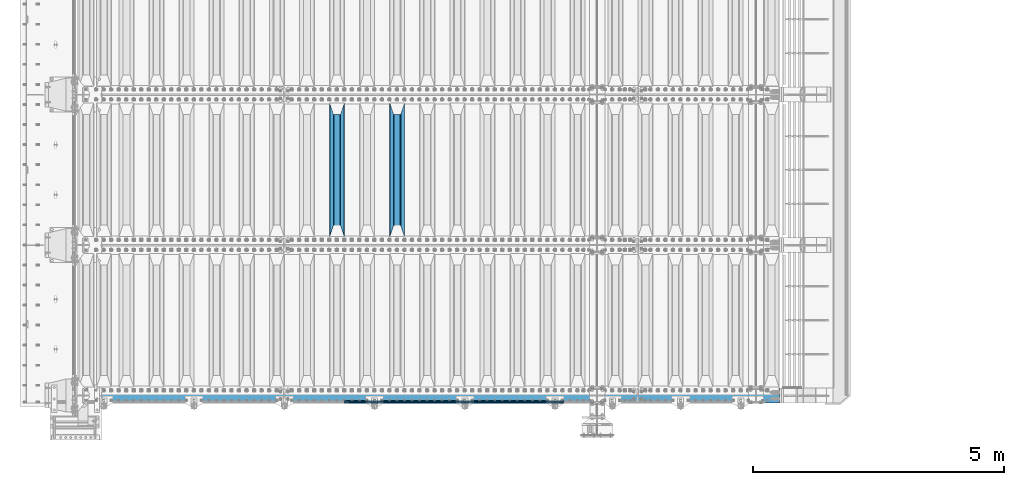
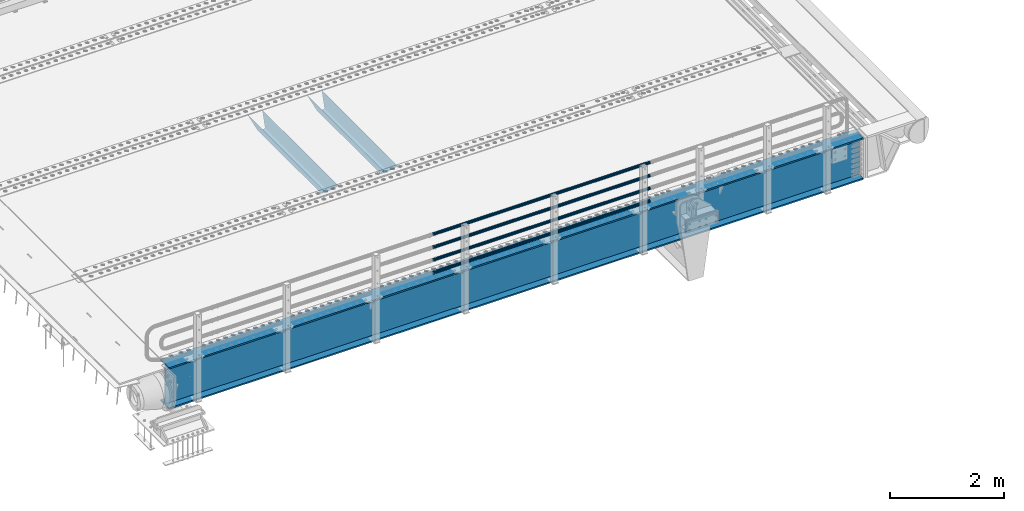
# One storey, part 104 of 240: 7 beams.
"""IFC2X3 building model written with IfcOpenShell, lengths in millimetres."""

import ifcopenshell
import ifcopenshell.guid

model = None  # the IFC model being written
_history = None  # IfcOwnerHistory: only IFC2X3 demands one
_inside = {}  # id of a spatial element -> (the spatial element, [elements in it])
_under = {}  # id of a project, library or spatial element -> (it, [spatial elements below it])
_declared = {}  # id of a project -> (the project, [libraries it declares])
_typed = {}  # id of a type object -> (the type object, [elements of that type])
_made_of = {}  # id of a material, layer set ... -> (it, [elements and type objects made of it])


def new_model(schema):
    """Start an empty IFC model of exactly this schema.

    Asked for "IFC4X3", IfcOpenShell would pick the latest addendum, in which some entities
    have other attributes; the version numbers below select the first issue.
    IFC2X3 requires an IfcOwnerHistory on every rooted entity: one is made here for all.
    """
    global model, _history
    if schema == "IFC4X3":
        model = ifcopenshell.file(schema_version=(4, 3, 0, 0))
    else:
        model = ifcopenshell.file(schema=schema)
    _inside.clear()
    _under.clear()
    _declared.clear()
    _typed.clear()
    _made_of.clear()
    _history = None
    if model.schema == "IFC2X3":
        org = make("IfcOrganization", Name="unknown")
        user = make(
            "IfcPersonAndOrganization",
            ThePerson=make("IfcPerson", FamilyName="unknown"),
            TheOrganization=org,
        )
        app = make(
            "IfcApplication",
            ApplicationDeveloper=org,
            Version="unknown",
            ApplicationFullName="unknown",
            ApplicationIdentifier="unknown",
        )
        _history = make(
            "IfcOwnerHistory",
            OwningUser=user,
            OwningApplication=app,
            ChangeAction="ADDED",
            CreationDate=0,
        )
    return model


def make(cls, **values):
    """One entity of the class cls with the attributes given. An attribute that is None is left unset."""
    return model.create_entity(
        cls, **{name: value for name, value in values.items() if value is not None}
    )


def rooted(cls, **values):
    """An entity with a GlobalId (a new one), such as an element, a storey or a relation."""
    return make(cls, GlobalId=ifcopenshell.guid.new(), OwnerHistory=_history, **values)


def si_unit(unit_type, name, prefix=None):
    """IfcSIUnit, for example si_unit("LENGTHUNIT", "METRE", prefix="MILLI")."""
    return make("IfcSIUnit", UnitType=unit_type, Prefix=prefix, Name=name)


def assignment(units):
    """IfcUnitAssignment: the units of a project."""
    return None if units is None else make("IfcUnitAssignment", Units=units)


def point(xyz):
    """IfcCartesianPoint."""
    return None if xyz is None else make("IfcCartesianPoint", Coordinates=xyz)


def direction(xyz):
    """IfcDirection."""
    return None if xyz is None else make("IfcDirection", DirectionRatios=xyz)


def frame(location, z_axis=None, x_axis=None):
    """IfcAxis2Placement3D, a coordinate frame: its origin and axes. An axis left out is left unset."""
    return make(
        "IfcAxis2Placement3D",
        Location=point(location),
        Axis=direction(z_axis),
        RefDirection=direction(x_axis),
    )


def origin_with_axes():
    """The frame at (0, 0, 0) with the z axis (0, 0, 1) and the x axis (1, 0, 0) written out."""
    return frame((0.0, 0.0, 0.0), z_axis=(0.0, 0.0, 1.0), x_axis=(1.0, 0.0, 0.0))


def place(relative_to, where):
    """IfcLocalPlacement: puts the frame where relative to a parent placement (None: the world)."""
    return make(
        "IfcLocalPlacement", PlacementRelTo=relative_to, RelativePlacement=where
    )


def context(
    kind, dimensions, precision=None, world=None, true_north=None, identifier=None
):
    """IfcGeometricRepresentationContext, for example the 3D "Model" context."""
    return make(
        "IfcGeometricRepresentationContext",
        ContextIdentifier=identifier,
        ContextType=kind,
        CoordinateSpaceDimension=dimensions,
        Precision=precision,
        WorldCoordinateSystem=world,
        TrueNorth=true_north,
    )


def subcontext(parent, identifier, kind, view, scale=None):
    """IfcGeometricRepresentationSubContext, for example "Body" below "Model"."""
    return make(
        "IfcGeometricRepresentationSubContext",
        ContextIdentifier=identifier,
        ContextType=kind,
        ParentContext=parent,
        TargetScale=scale,
        TargetView=view,
    )


def project(units=None, contexts=None):
    """IfcProject with its units and contexts."""
    return rooted(
        "IfcProject",
        Name="project",
        RepresentationContexts=contexts,
        UnitsInContext=assignment(units),
    )


def spatial(cls, under=None, at=None, **own):
    """A site, building, storey or space (cls), placed at a placement, below another one or the project."""
    s = rooted(cls, ObjectPlacement=at, **own)
    if under is not None:
        _under.setdefault(under.id(), (under, []))[1].append(s)
    return s


def faces_of(points, faces, orient=None, outer=None):
    """IfcFace entities. A face is a list of loops; a loop is a list of indices into points, from 0.

    orient and outer hold one flag for each loop. By default every Orientation is true, the
    first loop of a face is its IfcFaceOuterBound and the others are IfcFaceBound.
    """
    made = []
    for i, loops in enumerate(faces):
        bounds = []
        for j, loop in enumerate(loops):
            is_outer = j == 0 if outer is None else outer[i][j]
            bounds.append(
                make(
                    "IfcFaceOuterBound" if is_outer else "IfcFaceBound",
                    Bound=make("IfcPolyLoop", Polygon=[points[k] for k in loop]),
                    Orientation=True if orient is None else orient[i][j],
                )
            )
        made.append(make("IfcFace", Bounds=bounds))
    return made


def faceted_brep(points, faces, orient=None, outer=None, voids=None):
    """IfcFacetedBrep: a solid bounded by flat faces; with voids (closed shells), ...WithVoids."""
    shared = [point(p) for p in points]
    hull = make("IfcClosedShell", CfsFaces=faces_of(shared, faces, orient, outer))
    if voids is None:
        return make("IfcFacetedBrep", Outer=hull)
    return make(
        "IfcFacetedBrepWithVoids",
        Outer=hull,
        Voids=[
            make(cls, CfsFaces=faces_of(shared, fs, o, b)) for cls, fs, o, b in voids
        ],
    )


def shape(context_of_items, identifier, shape_type, items):
    """IfcShapeRepresentation: the items that make up one representation, for example the "Body"."""
    return make(
        "IfcShapeRepresentation",
        ContextOfItems=context_of_items,
        RepresentationIdentifier=identifier,
        RepresentationType=shape_type,
        Items=items,
    )


def material(Name=None, Category=None):
    """IfcMaterial."""
    return make("IfcMaterial", Name=Name, Category=Category)


def made_of(thing, what):
    """Note that an element or type object is made of a material, layer set ...; save() writes the relation."""
    if what is not None:
        _made_of.setdefault(what.id(), (what, []))[1].append(thing)
    return thing


def type_object(cls, material=None, **own):
    """A type object (cls), such as IfcWallType, which elements share."""
    return made_of(rooted(cls, **own), material)


def element(
    cls,
    number,
    at=None,
    inside=None,
    cuts=None,
    type_object=None,
    material=None,
    context=None,
    identifier="Body",
    shape_type=None,
    held_by="IfcProductDefinitionShape",
    body=None,
    shapes=None,
    **own,
):
    """One element of the class cls, such as IfcWall. Its Tag is "e" and its number.

    at: its placement. inside: the storey or other place that contains it. cuts: it is an
    opening in that element (IfcRelVoidsElement). A single representation is given by context,
    identifier, shape_type and body (its items); several are given by shapes. held_by: the class
    of the entity that holds the representations. save() writes the other relations.
    """
    e = rooted(cls, Tag="e%d" % number, ObjectPlacement=at, **own)
    if body is not None:
        shapes = [shape(context, identifier, shape_type, body)]
    if shapes is not None:
        e.Representation = make(held_by, Representations=shapes)
    if inside is not None:
        _inside.setdefault(inside.id(), (inside, []))[1].append(e)
    if cuts is not None:
        rooted(
            "IfcRelVoidsElement", RelatingBuildingElement=cuts, RelatedOpeningElement=e
        )
    if type_object is not None:
        _typed.setdefault(type_object.id(), (type_object, []))[1].append(e)
    return made_of(e, material)


def aggregate(whole, parts):
    """IfcRelAggregates: a whole, such as a stair, and the parts it consists of."""
    return rooted("IfcRelAggregates", RelatingObject=whole, RelatedObjects=parts)


def save(model, path):
    """Write the relations noted so far, then the file.

    IfcRelAggregates (storeys below a building ...), IfcRelContainedInSpatialStructure (elements
    in a storey), IfcRelDefinesByType, IfcRelAssociatesMaterial and IfcRelDeclares: one each for
    every whole, place, type object, material and project.
    """
    for whole, parts in _under.values():
        aggregate(whole, parts)
    for where, things in _inside.values():
        rooted(
            "IfcRelContainedInSpatialStructure",
            RelatedElements=things,
            RelatingStructure=where,
        )
    for kind, things in _typed.values():
        rooted("IfcRelDefinesByType", RelatedObjects=things, RelatingType=kind)
    for what, things in _made_of.values():
        rooted("IfcRelAssociatesMaterial", RelatedObjects=things, RelatingMaterial=what)
    for by, libraries in _declared.values():
        rooted("IfcRelDeclares", RelatingContext=by, RelatedDefinitions=libraries)
    model.write(path)


model = new_model("IFC2X3")

# Units and contexts
model_context = context("Model", 3, precision=1e-05, world=origin_with_axes())
body_context = subcontext(model_context, "Body", "Model", "MODEL_VIEW")
ifc_project = project(units=[si_unit("LENGTHUNIT", "METRE", prefix="MILLI"), si_unit("AREAUNIT", "SQUARE_METRE"), si_unit("VOLUMEUNIT", "CUBIC_METRE"), si_unit("MASSUNIT", "GRAM", prefix="KILO"), si_unit("TIMEUNIT", "SECOND"), si_unit("PLANEANGLEUNIT", "RADIAN"), si_unit("SOLIDANGLEUNIT", "STERADIAN"), si_unit("THERMODYNAMICTEMPERATUREUNIT", "DEGREE_CELSIUS"), si_unit("LUMINOUSINTENSITYUNIT", "LUMEN")], contexts=[model_context])

# Site, building, storey
site_placement = place(None, origin_with_axes())
site = spatial("IfcSite", under=ifc_project, at=site_placement, CompositionType="ELEMENT")
building_placement = place(site_placement, origin_with_axes())
building = spatial("IfcBuilding", under=site, at=building_placement, Name="Standard", CompositionType="ELEMENT")
storey_placement = place(building_placement, origin_with_axes())
storey = spatial("IfcBuildingStorey", under=building, at=storey_placement, Name="Undefined", CompositionType="ELEMENT", Elevation=0.0)

# Beams
ifc_material_1 = material(Name="STEEL/S355N")
beam_type_1 = type_object("IfcBeamType", PredefinedType="NOTDEFINED")
beam_1_placement = place(storey_placement, frame((48850.0, 27175.0, -115.0), z_axis=(0.0, 0.0, 1.0), x_axis=(0.0, 1.0, 0.0)))
element("IfcBeam", 1, at=beam_1_placement, inside=storey, type_object=beam_type_1, material=ifc_material_1, context=body_context, shape_type="Brep", body=[
    faceted_brep([(0.0, 150.0, 115.0), (0.0, 143.690000000002, 115.0), (2650.00000000297, 143.690000000002, 115.0), (2650.00000000297, 150.0, 115.0), (2650.00000000297, 142.059565218406, 110.000000003094), (2650.00000000297, 148.369565218403, 110.000000003094), (2441.90079219209, -80.1103600731149, -98.0992078077845), (2437.7588105432, -77.5672621345584, -102.241189456673), (2434.06523489747, -74.4080125315522, -105.934765102404), (2430.9108609509, -70.7102721255724, -109.089139048974), (2428.37322971128, -66.5649389910031, -111.626770288588), (2426.51472138055, -62.0739139532889, -113.485278619323), (2425.38102192092, -57.3475956567636, -114.618978078955), (2424.99999999987, -52.5021667386536, -115.0), (2424.99999999987, 52.5021667386536, -115.0), (2425.38102192092, 57.3475956567636, -114.618978078955), (2426.51472138055, 62.0739139532889, -113.485278619323), (2428.37322971128, 66.5649389910031, -111.626770288588), (2430.9108609509, 70.7102721255724, -109.089139048974), (2434.06523489747, 74.4080125315522, -105.934765102404), (2437.7588105432, 77.5672621345584, -102.241189456673), (2441.90079219209, 80.1103600731149, -98.0992078077846), (2446.38936140512, 81.9747917625791, -93.6106385947584), (2448.2494850041, 76.2713538057287, -91.7505149957729), (2444.62967112263, 74.76777986261, -95.3703288772456), (2441.28936334127, 72.7168944282894, -98.710636658607), (2438.31067330439, 70.1691124903809, -101.689326695487), (2435.76682334748, 67.1870637758839, -104.233176652398), (2433.72034654134, 63.8440531834931, -106.279653458539), (2432.22154950042, 60.2222587982324, -107.778450499454), (2431.30727574265, 56.4107117849126, -108.692724257221), (2430.99999999987, 52.5031078186876, -109.0), (2430.99999999987, -52.5031078186876, -109.0), (2431.30727574265, -56.4107117849126, -108.692724257221), (2432.22154950042, -60.2222587982324, -107.778450499454), (2433.72034654134, -63.8440531834931, -106.279653458539), (2435.76682334748, -67.1870637758839, -104.233176652398), (2438.31067330439, -70.1691124903809, -101.689326695487), (2441.28936334127, -72.7168944282894, -98.7106366586071), (2444.62967112263, -74.76777986261, -95.3703288772457), (2448.2494850041, -76.2713538057287, -91.7505149957729), (2650.00000000297, -142.059565218406, 110.000000003094), (2650.00000000297, -148.369565218403, 110.000000003094), (2446.38936140512, -81.9747917625791, -93.6106385947584), (2650.00000000297, -143.690000000002, 115.0), (2650.00000000297, -150.0, 115.0), (0.0, -143.690000000002, 115.0), (0.0, -150.0, 115.0), (0.0, -148.369565218258, 110.000000002667), (203.610638597427, -81.9747917625791, -93.6106385947584), (208.09920781045, -80.1103600731149, -98.0992078077845), (212.241189459342, -77.5672621345584, -102.241189456673), (215.93476510507, -74.4080125315522, -105.934765102404), (219.089139051641, -70.7102721255724, -109.089139048974), (221.626770291256, -66.5649389910031, -111.626770288588), (223.485278621989, -62.0739139532889, -113.485278619323), (224.618978081624, -57.3475956567636, -114.618978078955), (225.000000002663, -52.5021667386536, -115.0), (225.000000002663, 52.5021667386536, -115.0), (224.618978081624, 57.3475956567636, -114.618978078955), (223.485278621989, 62.0739139532889, -113.485278619323), (221.626770291256, 66.5649389910031, -111.626770288588), (219.089139051641, 70.7102721255724, -109.089139048974), (215.93476510507, 74.4080125315522, -105.934765102404), (212.241189459342, 77.5672621345584, -102.241189456673), (208.09920781045, 80.1103600731149, -98.0992078077846), (203.610638597427, 81.9747917625791, -93.6106385947584), (0.0, 148.369565218258, 110.000000002667), (0.0, 142.05956521826, 110.000000002667), (201.750514998439, 76.2713538057287, -91.7505149957729), (205.370328879908, 74.76777986261, -95.3703288772456), (208.710636661275, 72.7168944282894, -98.710636658607), (211.689326698153, 70.1691124903809, -101.689326695487), (214.233176655063, 67.1870637758839, -104.233176652398), (216.279653461206, 63.8440531834931, -106.279653458539), (217.778450502123, 60.2222587982324, -107.778450499454), (218.692724259887, 56.4107117849126, -108.692724257221), (219.000000002667, 52.5031078186876, -109.0), (219.000000002667, -52.5031078186876, -109.0), (218.692724259887, -56.4107117849126, -108.692724257221), (217.778450502123, -60.2222587982324, -107.778450499454), (216.279653461206, -63.8440531834931, -106.279653458539), (214.233176655063, -67.1870637758839, -104.233176652398), (211.689326698153, -70.1691124903809, -101.689326695487), (208.710636661275, -72.7168944282894, -98.7106366586071), (205.370328879915, -74.76777986261, -95.3703288772457), (201.750514998439, -76.2713538057287, -91.7505149957729), (0.0, -142.05956521826, 110.000000002667)], [[[0, 1, 2, 3]], [[3, 2, 4, 5]], [[6, 7, 8, 9, 10, 11, 12, 13, 14, 15, 16, 17, 18, 19, 20, 21, 22, 5, 4, 23, 24, 25, 26, 27, 28, 29, 30, 31, 32, 33, 34, 35, 36, 37, 38, 39, 40, 41, 42, 43]], [[44, 45, 42, 41]], [[46, 47, 45, 44]], [[43, 42, 45, 47, 48, 49]], [[6, 43, 49, 50]], [[7, 6, 50, 51]], [[8, 7, 51, 52]], [[9, 8, 52, 53]], [[10, 9, 53, 54]], [[11, 10, 54, 55]], [[12, 11, 55, 56]], [[13, 12, 56, 57]], [[14, 13, 57, 58]], [[15, 14, 58, 59]], [[16, 15, 59, 60]], [[17, 16, 60, 61]], [[18, 17, 61, 62]], [[19, 18, 62, 63]], [[20, 19, 63, 64]], [[21, 20, 64, 65]], [[22, 21, 65, 66]], [[0, 3, 5, 22, 66, 67]], [[1, 0, 67, 68]], [[23, 4, 2, 1, 68, 69]], [[24, 23, 69, 70]], [[25, 24, 70, 71]], [[26, 25, 71, 72]], [[27, 26, 72, 73]], [[28, 27, 73, 74]], [[29, 28, 74, 75]], [[30, 29, 75, 76]], [[31, 30, 76, 77]], [[32, 31, 77, 78]], [[33, 32, 78, 79]], [[34, 33, 79, 80]], [[35, 34, 80, 81]], [[36, 35, 81, 82]], [[37, 36, 82, 83]], [[38, 37, 83, 84]], [[39, 38, 84, 85]], [[40, 39, 85, 86]], [[46, 44, 41, 40, 86, 87]], [[47, 46, 87, 48]], [[86, 85, 84, 83, 82, 81, 80, 79, 78, 77, 76, 75, 74, 73, 72, 71, 70, 69, 68, 67, 66, 65, 64, 63, 62, 61, 60, 59, 58, 57, 56, 55, 54, 53, 52, 51, 50, 49, 48, 87]]]),
])
beam_2_placement = place(storey_placement, frame((47650.0, 27175.0, -115.0), z_axis=(0.0, 0.0, 1.0), x_axis=(0.0, 1.0, 0.0)))
element("IfcBeam", 2, at=beam_2_placement, inside=storey, type_object=beam_type_1, material=ifc_material_1, context=body_context, shape_type="Brep", body=[
    faceted_brep([(0.0, 150.0, 115.0), (0.0, 143.690000000002, 115.0), (2650.00000000297, 143.690000000002, 115.0), (2650.00000000297, 150.0, 115.0), (2650.00000000297, 142.059565218406, 110.000000003094), (2650.00000000297, 148.369565218403, 110.000000003094), (2441.90079219209, -80.1103600731149, -98.0992078077845), (2437.7588105432, -77.5672621345584, -102.241189456673), (2434.06523489747, -74.4080125315522, -105.934765102404), (2430.9108609509, -70.7102721255724, -109.089139048974), (2428.37322971128, -66.5649389910031, -111.626770288588), (2426.51472138055, -62.0739139532889, -113.485278619323), (2425.38102192092, -57.3475956567636, -114.618978078955), (2424.99999999987, -52.5021667386536, -115.0), (2424.99999999987, 52.5021667386536, -115.0), (2425.38102192092, 57.3475956567636, -114.618978078955), (2426.51472138055, 62.0739139532889, -113.485278619323), (2428.37322971128, 66.5649389910031, -111.626770288588), (2430.9108609509, 70.7102721255724, -109.089139048974), (2434.06523489747, 74.4080125315522, -105.934765102404), (2437.7588105432, 77.5672621345584, -102.241189456673), (2441.90079219209, 80.1103600731149, -98.0992078077846), (2446.38936140512, 81.9747917625791, -93.6106385947584), (2448.2494850041, 76.2713538057287, -91.7505149957729), (2444.62967112263, 74.76777986261, -95.3703288772456), (2441.28936334127, 72.7168944282894, -98.710636658607), (2438.31067330439, 70.1691124903809, -101.689326695487), (2435.76682334748, 67.1870637758839, -104.233176652398), (2433.72034654134, 63.8440531834931, -106.279653458539), (2432.22154950042, 60.2222587982324, -107.778450499454), (2431.30727574265, 56.4107117849126, -108.692724257221), (2430.99999999987, 52.5031078186876, -109.0), (2430.99999999987, -52.5031078186876, -109.0), (2431.30727574265, -56.4107117849126, -108.692724257221), (2432.22154950042, -60.2222587982324, -107.778450499454), (2433.72034654134, -63.8440531834931, -106.279653458539), (2435.76682334748, -67.1870637758839, -104.233176652398), (2438.31067330439, -70.1691124903809, -101.689326695487), (2441.28936334127, -72.7168944282894, -98.7106366586071), (2444.62967112263, -74.76777986261, -95.3703288772457), (2448.2494850041, -76.2713538057287, -91.7505149957729), (2650.00000000297, -142.059565218406, 110.000000003094), (2650.00000000297, -148.369565218403, 110.000000003094), (2446.38936140512, -81.9747917625791, -93.6106385947584), (2650.00000000297, -143.690000000002, 115.0), (2650.00000000297, -150.0, 115.0), (0.0, -143.690000000002, 115.0), (0.0, -150.0, 115.0), (0.0, -148.369565218258, 110.000000002667), (203.610638597427, -81.9747917625791, -93.6106385947584), (208.09920781045, -80.1103600731149, -98.0992078077845), (212.241189459342, -77.5672621345584, -102.241189456673), (215.93476510507, -74.4080125315522, -105.934765102404), (219.089139051641, -70.7102721255724, -109.089139048974), (221.626770291256, -66.5649389910031, -111.626770288588), (223.485278621989, -62.0739139532889, -113.485278619323), (224.618978081624, -57.3475956567636, -114.618978078955), (225.000000002663, -52.5021667386536, -115.0), (225.000000002663, 52.5021667386536, -115.0), (224.618978081624, 57.3475956567636, -114.618978078955), (223.485278621989, 62.0739139532889, -113.485278619323), (221.626770291256, 66.5649389910031, -111.626770288588), (219.089139051641, 70.7102721255724, -109.089139048974), (215.93476510507, 74.4080125315522, -105.934765102404), (212.241189459342, 77.5672621345584, -102.241189456673), (208.09920781045, 80.1103600731149, -98.0992078077846), (203.610638597427, 81.9747917625791, -93.6106385947584), (0.0, 148.369565218258, 110.000000002667), (0.0, 142.05956521826, 110.000000002667), (201.750514998439, 76.2713538057287, -91.7505149957729), (205.370328879908, 74.76777986261, -95.3703288772456), (208.710636661275, 72.7168944282894, -98.710636658607), (211.689326698153, 70.1691124903809, -101.689326695487), (214.233176655063, 67.1870637758839, -104.233176652398), (216.279653461206, 63.8440531834931, -106.279653458539), (217.778450502123, 60.2222587982324, -107.778450499454), (218.692724259887, 56.4107117849126, -108.692724257221), (219.000000002667, 52.5031078186876, -109.0), (219.000000002667, -52.5031078186876, -109.0), (218.692724259887, -56.4107117849126, -108.692724257221), (217.778450502123, -60.2222587982324, -107.778450499454), (216.279653461206, -63.8440531834931, -106.279653458539), (214.233176655063, -67.1870637758839, -104.233176652398), (211.689326698153, -70.1691124903809, -101.689326695487), (208.710636661275, -72.7168944282894, -98.7106366586071), (205.370328879915, -74.76777986261, -95.3703288772457), (201.750514998439, -76.2713538057287, -91.7505149957729), (0.0, -142.05956521826, 110.000000002667)], [[[0, 1, 2, 3]], [[3, 2, 4, 5]], [[6, 7, 8, 9, 10, 11, 12, 13, 14, 15, 16, 17, 18, 19, 20, 21, 22, 5, 4, 23, 24, 25, 26, 27, 28, 29, 30, 31, 32, 33, 34, 35, 36, 37, 38, 39, 40, 41, 42, 43]], [[44, 45, 42, 41]], [[46, 47, 45, 44]], [[43, 42, 45, 47, 48, 49]], [[6, 43, 49, 50]], [[7, 6, 50, 51]], [[8, 7, 51, 52]], [[9, 8, 52, 53]], [[10, 9, 53, 54]], [[11, 10, 54, 55]], [[12, 11, 55, 56]], [[13, 12, 56, 57]], [[14, 13, 57, 58]], [[15, 14, 58, 59]], [[16, 15, 59, 60]], [[17, 16, 60, 61]], [[18, 17, 61, 62]], [[19, 18, 62, 63]], [[20, 19, 63, 64]], [[21, 20, 64, 65]], [[22, 21, 65, 66]], [[0, 3, 5, 22, 66, 67]], [[1, 0, 67, 68]], [[23, 4, 2, 1, 68, 69]], [[24, 23, 69, 70]], [[25, 24, 70, 71]], [[26, 25, 71, 72]], [[27, 26, 72, 73]], [[28, 27, 73, 74]], [[29, 28, 74, 75]], [[30, 29, 75, 76]], [[31, 30, 76, 77]], [[32, 31, 77, 78]], [[33, 32, 78, 79]], [[34, 33, 79, 80]], [[35, 34, 80, 81]], [[36, 35, 81, 82]], [[37, 36, 82, 83]], [[38, 37, 83, 84]], [[39, 38, 84, 85]], [[40, 39, 85, 86]], [[46, 44, 41, 40, 86, 87]], [[47, 46, 87, 48]], [[86, 85, 84, 83, 82, 81, 80, 79, 78, 77, 76, 75, 74, 73, 72, 71, 70, 69, 68, 67, 66, 65, 64, 63, 62, 61, 60, 59, 58, 57, 56, 55, 54, 53, 52, 51, 50, 49, 48, 87]]]),
])
ifc_material_2 = material()
beam_type_2 = type_object("IfcBeamType", PredefinedType="NOTDEFINED")
beam_3_placement = place(storey_placement, frame((52177.9999999999, 23870.1500000001, 149.849999999748), z_axis=(0.0, 0.0, -1.0), x_axis=(-1.0, 0.0, 0.0)))
element("IfcBeam", 3, at=beam_3_placement, inside=storey, type_object=beam_type_2, material=ifc_material_2, context=body_context, shape_type="Brep", body=[
    faceted_brep([(0.0, -26.5500000000029, 0.0), (0.0, -24.5290015881765, 10.1602451292931), (4384.00249699992, -24.5290015881765, 10.1602451292931), (4384.00249699992, -26.5500000000029, 0.0), (0.0, -18.7736850405054, 18.7736850405028), (4384.00249699992, -18.7736850405054, 18.7736850405028), (0.0, -10.1602451292929, 24.5290015881747), (4384.00249699992, -10.1602451292929, 24.5290015881747), (0.0, 0.0, 26.55), (4384.00249699992, 0.0, 26.55), (0.0, 10.1602451292929, 24.5290015881747), (4384.00249699992, 10.1602451292929, 24.5290015881747), (0.0, 18.7736850405054, 18.7736850405028), (4384.00249699992, 18.7736850405054, 18.7736850405028), (0.0, 24.5290015881765, 10.1602451292931), (4384.00249699992, 24.5290015881765, 10.1602451292931), (0.0, 26.5500000000029, 0.0), (4384.00249699992, 26.5500000000029, 0.0), (0.0, 24.5290015881765, -10.1602451292931), (4384.00249699992, 24.5290015881765, -10.1602451292931), (0.0, 18.7736850405054, -18.7736850405028), (4384.00249699992, 18.7736850405054, -18.7736850405028), (0.0, 10.1602451292929, -24.5290015881747), (4384.00249699992, 10.1602451292929, -24.5290015881747), (0.0, 0.0, -26.55), (4384.00249699992, 0.0, -26.55), (0.0, -10.1602451292929, -24.5290015881747), (4384.00249699992, -10.1602451292929, -24.5290015881747), (0.0, -18.7736850405054, -18.7736850405028), (4384.00249699992, -18.7736850405054, -18.7736850405028), (0.0, -24.5290015881765, -10.1602451292931), (4384.00249699992, -24.5290015881765, -10.1602451292931), (0.0, -30.1500000000015, 0.0), (0.0, -27.8549679052157, -11.5379054858058), (4384.00249699992, -27.8549679052157, -11.5379054858075), (4384.00249699992, -30.1500000000015, 0.0), (0.0, -21.3192694527752, -21.3192694527752), (4384.00249699992, -21.3192694527752, -21.3192694527744), (0.0, -11.5379054858058, -27.8549679052157), (4384.00249699992, -11.5379054858058, -27.8549679052153), (0.0, 0.0, -30.1500000000015), (4384.00249699992, 0.0, -30.15), (0.0, 11.5379054858058, -27.8549679052157), (4384.00249699992, 11.5379054858058, -27.8549679052153), (0.0, 21.3192694527752, -21.3192694527752), (4384.00249699992, 21.3192694527752, -21.3192694527744), (0.0, 27.8549679052157, -11.5379054858058), (4384.00249699992, 27.8549679052157, -11.5379054858074), (0.0, 30.1500000000015, 0.0), (4384.00249699992, 30.1500000000015, 0.0), (0.0, 27.8549679052157, 11.5379054858058), (4384.00249699992, 27.8549679052157, 11.5379054858075), (0.0, 21.3192694527752, 21.3192694527752), (4384.00249699992, 21.3192694527752, 21.3192694527744), (0.0, 11.5379054858058, 27.8549679052157), (4384.00249699992, 11.5379054858058, 27.8549679052153), (0.0, 0.0, 30.1500000000015), (4384.00249699992, 0.0, 30.15), (0.0, -11.5379054858058, 27.8549679052157), (4384.00249699992, -11.5379054858058, 27.8549679052153), (0.0, -21.3192694527752, 21.3192694527752), (4384.00249699992, -21.3192694527752, 21.3192694527744), (0.0, -27.8549679052157, 11.5379054858058), (4384.00249699992, -27.8549679052157, 11.5379054858075)], [[[0, 1, 2, 3]], [[1, 4, 5, 2]], [[4, 6, 7, 5]], [[6, 8, 9, 7]], [[8, 10, 11, 9]], [[10, 12, 13, 11]], [[12, 14, 15, 13]], [[14, 16, 17, 15]], [[16, 18, 19, 17]], [[18, 20, 21, 19]], [[20, 22, 23, 21]], [[22, 24, 25, 23]], [[24, 26, 27, 25]], [[26, 28, 29, 27]], [[28, 30, 31, 29]], [[30, 0, 3, 31]], [[32, 33, 34, 35]], [[33, 36, 37, 34]], [[36, 38, 39, 37]], [[38, 40, 41, 39]], [[40, 42, 43, 41]], [[42, 44, 45, 43]], [[44, 46, 47, 45]], [[46, 48, 49, 47]], [[48, 50, 51, 49]], [[50, 52, 53, 51]], [[52, 54, 55, 53]], [[54, 56, 57, 55]], [[56, 58, 59, 57]], [[58, 60, 61, 59]], [[60, 62, 63, 61]], [[62, 32, 35, 63]], [[37, 39, 41, 43, 45, 47, 49, 51, 53, 55, 57, 59, 61, 63, 35, 34], [5, 7, 9, 11, 13, 15, 17, 19, 21, 23, 25, 27, 29, 31, 3, 2]], [[62, 60, 58, 56, 54, 52, 50, 48, 46, 44, 42, 40, 38, 36, 33, 32], [30, 28, 26, 24, 22, 20, 18, 16, 14, 12, 10, 8, 6, 4, 1, 0]]]),
])
beam_4_placement = place(storey_placement, frame((52177.9999999999, 23870.1500000001, 420.149999999748), z_axis=(0.0, 0.0, -1.0), x_axis=(-1.0, 0.0, 0.0)))
element("IfcBeam", 4, at=beam_4_placement, inside=storey, type_object=beam_type_2, material=ifc_material_2, context=body_context, shape_type="Brep", body=[
    faceted_brep([(0.0, -26.5500000000029, 0.0), (0.0, -24.5290015881765, 10.1602451292931), (4384.00249699992, -24.5290015881765, 10.1602451292931), (4384.00249699992, -26.5500000000029, 0.0), (0.0, -18.7736850405054, 18.7736850405028), (4384.00249699992, -18.7736850405054, 18.7736850405028), (0.0, -10.1602451292929, 24.5290015881747), (4384.00249699992, -10.1602451292929, 24.5290015881747), (0.0, 0.0, 26.55), (4384.00249699992, 0.0, 26.55), (0.0, 10.1602451292929, 24.5290015881747), (4384.00249699992, 10.1602451292929, 24.5290015881747), (0.0, 18.7736850405054, 18.7736850405028), (4384.00249699992, 18.7736850405054, 18.7736850405028), (0.0, 24.5290015881765, 10.1602451292931), (4384.00249699992, 24.5290015881765, 10.1602451292931), (0.0, 26.5500000000029, 0.0), (4384.00249699992, 26.5500000000029, 0.0), (0.0, 24.5290015881765, -10.1602451292931), (4384.00249699992, 24.5290015881765, -10.1602451292931), (0.0, 18.7736850405054, -18.7736850405028), (4384.00249699992, 18.7736850405054, -18.7736850405028), (0.0, 10.1602451292929, -24.5290015881747), (4384.00249699992, 10.1602451292929, -24.5290015881747), (0.0, 0.0, -26.55), (4384.00249699992, 0.0, -26.55), (0.0, -10.1602451292929, -24.5290015881747), (4384.00249699992, -10.1602451292929, -24.5290015881747), (0.0, -18.7736850405054, -18.7736850405028), (4384.00249699992, -18.7736850405054, -18.7736850405028), (0.0, -24.5290015881765, -10.1602451292931), (4384.00249699992, -24.5290015881765, -10.1602451292931), (0.0, -30.1500000000015, 0.0), (0.0, -27.8549679052157, -11.5379054858058), (4384.00249699992, -27.8549679052157, -11.5379054858075), (4384.00249699992, -30.1500000000015, 0.0), (0.0, -21.3192694527752, -21.3192694527752), (4384.00249699992, -21.3192694527752, -21.3192694527744), (0.0, -11.5379054858058, -27.8549679052157), (4384.00249699992, -11.5379054858058, -27.8549679052153), (0.0, 0.0, -30.1500000000015), (4384.00249699992, 0.0, -30.15), (0.0, 11.5379054858058, -27.8549679052157), (4384.00249699992, 11.5379054858058, -27.8549679052153), (0.0, 21.3192694527752, -21.3192694527752), (4384.00249699992, 21.3192694527752, -21.3192694527744), (0.0, 27.8549679052157, -11.5379054858058), (4384.00249699992, 27.8549679052157, -11.5379054858074), (0.0, 30.1500000000015, 0.0), (4384.00249699992, 30.1500000000015, 0.0), (0.0, 27.8549679052157, 11.5379054858058), (4384.00249699992, 27.8549679052157, 11.5379054858075), (0.0, 21.3192694527752, 21.3192694527752), (4384.00249699992, 21.3192694527752, 21.3192694527744), (0.0, 11.5379054858058, 27.8549679052157), (4384.00249699992, 11.5379054858058, 27.8549679052153), (0.0, 0.0, 30.1500000000015), (4384.00249699992, 0.0, 30.15), (0.0, -11.5379054858058, 27.8549679052157), (4384.00249699992, -11.5379054858058, 27.8549679052153), (0.0, -21.3192694527752, 21.3192694527752), (4384.00249699992, -21.3192694527752, 21.3192694527744), (0.0, -27.8549679052157, 11.5379054858058), (4384.00249699992, -27.8549679052157, 11.5379054858075)], [[[0, 1, 2, 3]], [[1, 4, 5, 2]], [[4, 6, 7, 5]], [[6, 8, 9, 7]], [[8, 10, 11, 9]], [[10, 12, 13, 11]], [[12, 14, 15, 13]], [[14, 16, 17, 15]], [[16, 18, 19, 17]], [[18, 20, 21, 19]], [[20, 22, 23, 21]], [[22, 24, 25, 23]], [[24, 26, 27, 25]], [[26, 28, 29, 27]], [[28, 30, 31, 29]], [[30, 0, 3, 31]], [[32, 33, 34, 35]], [[33, 36, 37, 34]], [[36, 38, 39, 37]], [[38, 40, 41, 39]], [[40, 42, 43, 41]], [[42, 44, 45, 43]], [[44, 46, 47, 45]], [[46, 48, 49, 47]], [[48, 50, 51, 49]], [[50, 52, 53, 51]], [[52, 54, 55, 53]], [[54, 56, 57, 55]], [[56, 58, 59, 57]], [[58, 60, 61, 59]], [[60, 62, 63, 61]], [[62, 32, 35, 63]], [[37, 39, 41, 43, 45, 47, 49, 51, 53, 55, 57, 59, 61, 63, 35, 34], [5, 7, 9, 11, 13, 15, 17, 19, 21, 23, 25, 27, 29, 31, 3, 2]], [[62, 60, 58, 56, 54, 52, 50, 48, 46, 44, 42, 40, 38, 36, 33, 32], [30, 28, 26, 24, 22, 20, 18, 16, 14, 12, 10, 8, 6, 4, 1, 0]]]),
])
beam_5_placement = place(storey_placement, frame((52177.9999999999, 23870.1500000001, 969.849999999748), z_axis=(0.0, 0.0, -1.0), x_axis=(-1.0, 0.0, 0.0)))
element("IfcBeam", 5, at=beam_5_placement, inside=storey, type_object=beam_type_2, material=ifc_material_2, context=body_context, shape_type="Brep", body=[
    faceted_brep([(0.0, -26.5500000000029, 0.0), (0.0, -24.5290015881765, 10.1602451292931), (4384.00249699992, -24.5290015881765, 10.1602451292931), (4384.00249699992, -26.5500000000029, 0.0), (0.0, -18.7736850405054, 18.7736850405028), (4384.00249699992, -18.7736850405054, 18.7736850405028), (0.0, -10.1602451292929, 24.5290015881747), (4384.00249699992, -10.1602451292929, 24.5290015881747), (0.0, 0.0, 26.55), (4384.00249699992, 0.0, 26.55), (0.0, 10.1602451292929, 24.5290015881747), (4384.00249699992, 10.1602451292929, 24.5290015881747), (0.0, 18.7736850405054, 18.7736850405028), (4384.00249699992, 18.7736850405054, 18.7736850405028), (0.0, 24.5290015881765, 10.1602451292931), (4384.00249699992, 24.5290015881765, 10.1602451292931), (0.0, 26.5500000000029, 0.0), (4384.00249699992, 26.5500000000029, 0.0), (0.0, 24.5290015881765, -10.1602451292931), (4384.00249699992, 24.5290015881765, -10.1602451292931), (0.0, 18.7736850405054, -18.7736850405028), (4384.00249699992, 18.7736850405054, -18.7736850405028), (0.0, 10.1602451292929, -24.5290015881747), (4384.00249699992, 10.1602451292929, -24.5290015881747), (0.0, 0.0, -26.55), (4384.00249699992, 0.0, -26.55), (0.0, -10.1602451292929, -24.5290015881747), (4384.00249699992, -10.1602451292929, -24.5290015881747), (0.0, -18.7736850405054, -18.7736850405028), (4384.00249699992, -18.7736850405054, -18.7736850405028), (0.0, -24.5290015881765, -10.1602451292931), (4384.00249699992, -24.5290015881765, -10.1602451292931), (0.0, -30.1500000000015, 0.0), (0.0, -27.8549679052157, -11.5379054858058), (4384.00249699992, -27.8549679052157, -11.5379054858075), (4384.00249699992, -30.1500000000015, 0.0), (0.0, -21.3192694527752, -21.3192694527752), (4384.00249699992, -21.3192694527752, -21.3192694527744), (0.0, -11.5379054858058, -27.8549679052157), (4384.00249699992, -11.5379054858058, -27.8549679052153), (0.0, 0.0, -30.1500000000015), (4384.00249699992, 0.0, -30.15), (0.0, 11.5379054858058, -27.8549679052157), (4384.00249699992, 11.5379054858058, -27.8549679052153), (0.0, 21.3192694527752, -21.3192694527752), (4384.00249699992, 21.3192694527752, -21.3192694527744), (0.0, 27.8549679052157, -11.5379054858058), (4384.00249699992, 27.8549679052157, -11.5379054858074), (0.0, 30.1500000000015, 0.0), (4384.00249699992, 30.1500000000015, 0.0), (0.0, 27.8549679052157, 11.5379054858058), (4384.00249699992, 27.8549679052157, 11.5379054858075), (0.0, 21.3192694527752, 21.3192694527752), (4384.00249699992, 21.3192694527752, 21.3192694527744), (0.0, 11.5379054858058, 27.8549679052157), (4384.00249699992, 11.5379054858058, 27.8549679052153), (0.0, 0.0, 30.1500000000015), (4384.00249699992, 0.0, 30.15), (0.0, -11.5379054858058, 27.8549679052157), (4384.00249699992, -11.5379054858058, 27.8549679052153), (0.0, -21.3192694527752, 21.3192694527752), (4384.00249699992, -21.3192694527752, 21.3192694527744), (0.0, -27.8549679052157, 11.5379054858058), (4384.00249699992, -27.8549679052157, 11.5379054858075)], [[[0, 1, 2, 3]], [[1, 4, 5, 2]], [[4, 6, 7, 5]], [[6, 8, 9, 7]], [[8, 10, 11, 9]], [[10, 12, 13, 11]], [[12, 14, 15, 13]], [[14, 16, 17, 15]], [[16, 18, 19, 17]], [[18, 20, 21, 19]], [[20, 22, 23, 21]], [[22, 24, 25, 23]], [[24, 26, 27, 25]], [[26, 28, 29, 27]], [[28, 30, 31, 29]], [[30, 0, 3, 31]], [[32, 33, 34, 35]], [[33, 36, 37, 34]], [[36, 38, 39, 37]], [[38, 40, 41, 39]], [[40, 42, 43, 41]], [[42, 44, 45, 43]], [[44, 46, 47, 45]], [[46, 48, 49, 47]], [[48, 50, 51, 49]], [[50, 52, 53, 51]], [[52, 54, 55, 53]], [[54, 56, 57, 55]], [[56, 58, 59, 57]], [[58, 60, 61, 59]], [[60, 62, 63, 61]], [[62, 32, 35, 63]], [[37, 39, 41, 43, 45, 47, 49, 51, 53, 55, 57, 59, 61, 63, 35, 34], [5, 7, 9, 11, 13, 15, 17, 19, 21, 23, 25, 27, 29, 31, 3, 2]], [[62, 60, 58, 56, 54, 52, 50, 48, 46, 44, 42, 40, 38, 36, 33, 32], [30, 28, 26, 24, 22, 20, 18, 16, 14, 12, 10, 8, 6, 4, 1, 0]]]),
])
beam_6_placement = place(storey_placement, frame((52177.9999999999, 23870.1500000001, 689.849999999748), z_axis=(0.0, 0.0, -1.0), x_axis=(-1.0, 0.0, 0.0)))
element("IfcBeam", 6, at=beam_6_placement, inside=storey, type_object=beam_type_2, material=ifc_material_2, context=body_context, shape_type="Brep", body=[
    faceted_brep([(0.0, -26.5500000000029, 0.0), (0.0, -24.5290015881765, 10.1602451292931), (4384.00249699992, -24.5290015881765, 10.1602451292931), (4384.00249699992, -26.5500000000029, 0.0), (0.0, -18.7736850405054, 18.7736850405028), (4384.00249699992, -18.7736850405054, 18.7736850405028), (0.0, -10.1602451292929, 24.5290015881747), (4384.00249699992, -10.1602451292929, 24.5290015881747), (0.0, 0.0, 26.55), (4384.00249699992, 0.0, 26.55), (0.0, 10.1602451292929, 24.5290015881747), (4384.00249699992, 10.1602451292929, 24.5290015881747), (0.0, 18.7736850405054, 18.7736850405028), (4384.00249699992, 18.7736850405054, 18.7736850405028), (0.0, 24.5290015881765, 10.1602451292931), (4384.00249699992, 24.5290015881765, 10.1602451292931), (0.0, 26.5500000000029, 0.0), (4384.00249699992, 26.5500000000029, 0.0), (0.0, 24.5290015881765, -10.1602451292931), (4384.00249699992, 24.5290015881765, -10.1602451292931), (0.0, 18.7736850405054, -18.7736850405028), (4384.00249699992, 18.7736850405054, -18.7736850405028), (0.0, 10.1602451292929, -24.5290015881747), (4384.00249699992, 10.1602451292929, -24.5290015881747), (0.0, 0.0, -26.55), (4384.00249699992, 0.0, -26.55), (0.0, -10.1602451292929, -24.5290015881747), (4384.00249699992, -10.1602451292929, -24.5290015881747), (0.0, -18.7736850405054, -18.7736850405028), (4384.00249699992, -18.7736850405054, -18.7736850405028), (0.0, -24.5290015881765, -10.1602451292931), (4384.00249699992, -24.5290015881765, -10.1602451292931), (0.0, -30.1500000000015, 0.0), (0.0, -27.8549679052157, -11.5379054858058), (4384.00249699992, -27.8549679052157, -11.5379054858075), (4384.00249699992, -30.1500000000015, 0.0), (0.0, -21.3192694527752, -21.3192694527752), (4384.00249699992, -21.3192694527752, -21.3192694527744), (0.0, -11.5379054858058, -27.8549679052157), (4384.00249699992, -11.5379054858058, -27.8549679052153), (0.0, 0.0, -30.1500000000015), (4384.00249699992, 0.0, -30.15), (0.0, 11.5379054858058, -27.8549679052157), (4384.00249699992, 11.5379054858058, -27.8549679052153), (0.0, 21.3192694527752, -21.3192694527752), (4384.00249699992, 21.3192694527752, -21.3192694527744), (0.0, 27.8549679052157, -11.5379054858058), (4384.00249699992, 27.8549679052157, -11.5379054858074), (0.0, 30.1500000000015, 0.0), (4384.00249699992, 30.1500000000015, 0.0), (0.0, 27.8549679052157, 11.5379054858058), (4384.00249699992, 27.8549679052157, 11.5379054858075), (0.0, 21.3192694527752, 21.3192694527752), (4384.00249699992, 21.3192694527752, 21.3192694527744), (0.0, 11.5379054858058, 27.8549679052157), (4384.00249699992, 11.5379054858058, 27.8549679052153), (0.0, 0.0, 30.1500000000015), (4384.00249699992, 0.0, 30.15), (0.0, -11.5379054858058, 27.8549679052157), (4384.00249699992, -11.5379054858058, 27.8549679052153), (0.0, -21.3192694527752, 21.3192694527752), (4384.00249699992, -21.3192694527752, 21.3192694527744), (0.0, -27.8549679052157, 11.5379054858058), (4384.00249699992, -27.8549679052157, 11.5379054858075)], [[[0, 1, 2, 3]], [[1, 4, 5, 2]], [[4, 6, 7, 5]], [[6, 8, 9, 7]], [[8, 10, 11, 9]], [[10, 12, 13, 11]], [[12, 14, 15, 13]], [[14, 16, 17, 15]], [[16, 18, 19, 17]], [[18, 20, 21, 19]], [[20, 22, 23, 21]], [[22, 24, 25, 23]], [[24, 26, 27, 25]], [[26, 28, 29, 27]], [[28, 30, 31, 29]], [[30, 0, 3, 31]], [[32, 33, 34, 35]], [[33, 36, 37, 34]], [[36, 38, 39, 37]], [[38, 40, 41, 39]], [[40, 42, 43, 41]], [[42, 44, 45, 43]], [[44, 46, 47, 45]], [[46, 48, 49, 47]], [[48, 50, 51, 49]], [[50, 52, 53, 51]], [[52, 54, 55, 53]], [[54, 56, 57, 55]], [[56, 58, 59, 57]], [[58, 60, 61, 59]], [[60, 62, 63, 61]], [[62, 32, 35, 63]], [[37, 39, 41, 43, 45, 47, 49, 51, 53, 55, 57, 59, 61, 63, 35, 34], [5, 7, 9, 11, 13, 15, 17, 19, 21, 23, 25, 27, 29, 31, 3, 2]], [[62, 60, 58, 56, 54, 52, 50, 48, 46, 44, 42, 40, 38, 36, 33, 32], [30, 28, 26, 24, 22, 20, 18, 16, 14, 12, 10, 8, 6, 4, 1, 0]]]),
])
beam_type_3 = type_object("IfcBeamType", Name="HEA900", PredefinedType="NOTDEFINED")
beam_7_placement = place(storey_placement, frame((42460.0, 24000.0, -445.0), z_axis=(0.0, 0.0, 1.0), x_axis=(1.0, 0.0, 0.0)))
element("IfcBeam", 7, at=beam_7_placement, inside=storey, type_object=beam_type_3, material=ifc_material_1, ObjectType="HEA900", context=body_context, shape_type="Brep", body=[
    faceted_brep([(0.0, 150.0, -445.0), (0.0, 150.0, -415.0), (14017.0, 150.0, -415.0), (14017.0, 150.0, -445.0), (0.0, 8.0, -415.0), (14017.0, 8.0, -415.0), (0.0, 8.0, 415.0), (14017.0, 8.0, 415.0), (0.0, 150.0, 415.0), (14017.0, 150.0, 415.0), (0.0, 150.0, 445.0), (14017.0, 150.0, 445.0), (0.0, -150.0, 445.0), (14017.0, -150.0, 445.0), (0.0, -150.0, 415.0), (14017.0, -150.0, 415.0), (0.0, -8.0, 415.0), (14017.0, -8.0, 415.0), (0.0, -8.0, -415.0), (14017.0, -8.0, -415.0), (0.0, -150.0, -415.0), (14017.0, -150.0, -415.0), (0.0, -150.0, -445.0), (14017.0, -150.0, -445.0)], [[[0, 1, 2, 3]], [[1, 4, 5, 2]], [[4, 6, 7, 5]], [[6, 8, 9, 7]], [[8, 10, 11, 9]], [[10, 12, 13, 11]], [[12, 14, 15, 13]], [[14, 16, 17, 15]], [[16, 18, 19, 17]], [[18, 20, 21, 19]], [[20, 22, 23, 21]], [[22, 0, 3, 23]], [[5, 7, 9, 11, 13, 15, 17, 19, 21, 23, 3, 2]], [[22, 20, 18, 16, 14, 12, 10, 8, 6, 4, 1, 0]]]),
])

save(model, "model.ifc")
